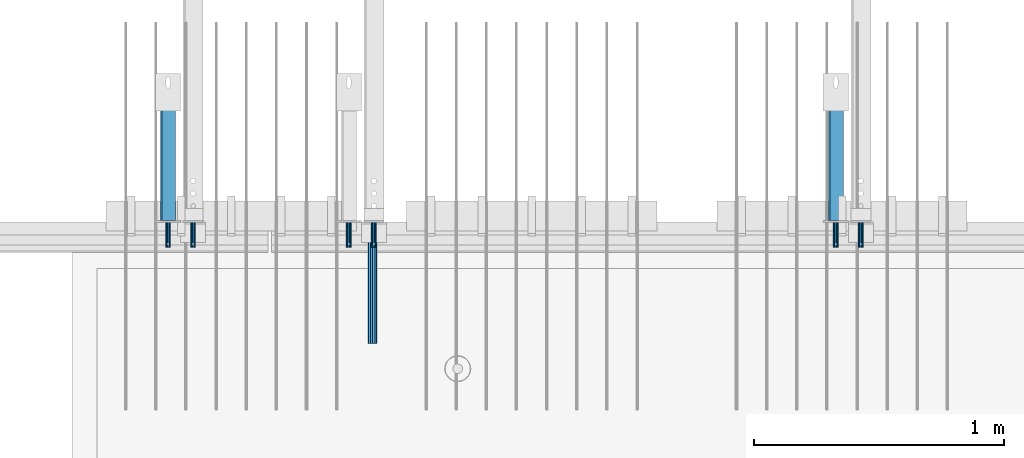
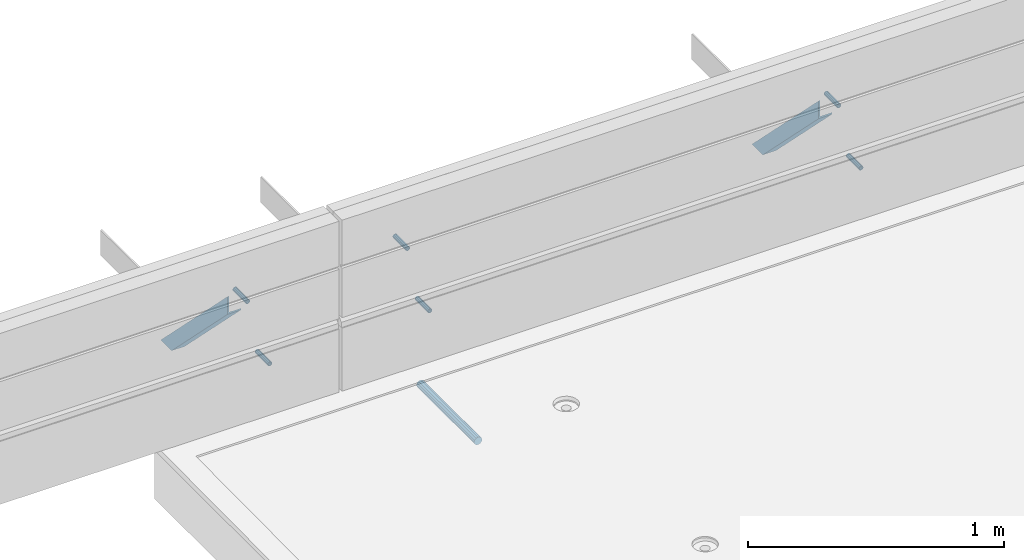
# One storey, part 50 of 153: 7 beams, 2 members, 12 elements without a shape of their own.
"""IFC2X3 building model written with IfcOpenShell, lengths in millimetres."""

from ifc_helpers import new_model, si_unit, frame, origin_with_axes, place, context, subcontext, project, spatial, faceted_brep, material, type_object, element, aggregate, save


model = new_model("IFC2X3")

# Units and contexts
model_context = context("Model", 3, precision=1e-05, world=origin_with_axes())
body_context = subcontext(model_context, "Body", "Model", "MODEL_VIEW")
ifc_project = project(units=[si_unit("LENGTHUNIT", "METRE", prefix="MILLI"), si_unit("AREAUNIT", "SQUARE_METRE"), si_unit("VOLUMEUNIT", "CUBIC_METRE"), si_unit("MASSUNIT", "GRAM", prefix="KILO"), si_unit("TIMEUNIT", "SECOND"), si_unit("PLANEANGLEUNIT", "RADIAN"), si_unit("SOLIDANGLEUNIT", "STERADIAN"), si_unit("THERMODYNAMICTEMPERATUREUNIT", "DEGREE_CELSIUS"), si_unit("LUMINOUSINTENSITYUNIT", "LUMEN")], contexts=[model_context])

# Site, building, storey
site_placement = place(None, origin_with_axes())
site = spatial("IfcSite", under=ifc_project, at=site_placement, CompositionType="ELEMENT")
building_placement = place(site_placement, origin_with_axes())
building = spatial("IfcBuilding", under=site, at=building_placement, CompositionType="ELEMENT")
storey_placement = place(building_placement, origin_with_axes())
storey = spatial("IfcBuildingStorey", under=building, at=storey_placement, Name="8", CompositionType="ELEMENT", Elevation=0.0)

# Assemblies, beams
assembly_1_placement = place(storey_placement, origin_with_axes())
assembly_1 = element("IfcElementAssembly", 1, at=assembly_1_placement, inside=storey, AssemblyPlace="NOTDEFINED", PredefinedType="REINFORCEMENT_UNIT")
assembly_2_placement = place(assembly_1_placement, origin_with_axes())
assembly_2 = element("IfcElementAssembly", 2, at=assembly_2_placement, Name="Steel Assembly", AssemblyPlace="NOTDEFINED", PredefinedType="RIGID_FRAME")
ifc_material_1 = material(Name="STEEL/Steel_Undefined")
beam_type_1 = type_object("IfcBeamType", PredefinedType="NOTDEFINED")
beam_1_placement = place(assembly_2_placement, frame((28925.0, 7665.0, 103315.0), z_axis=(1.0, 0.0, 0.0), x_axis=(0.0, -1.0, 0.0)))
beam_1 = element("IfcBeam", 3, at=beam_1_placement, type_object=beam_type_1, material=ifc_material_1, Name="1036-G", context=body_context, shape_type="Brep", body=[
    faceted_brep([(0.0, -8.49999999999272, -1.45519152283669e-11), (0.0, -7.36121593215648, 4.24999999998545), (100.000000000262, -7.36121593215648, 4.24999999998545), (100.000000000262, -8.49999999999272, -1.45519152283669e-11), (0.0, -4.24999999998545, 7.36121593216376), (100.000000000262, -4.24999999998545, 7.36121593216376), (0.0, 1.45519152283669e-11, 8.49999999998545), (100.000000000262, 1.45519152283669e-11, 8.49999999998545), (0.0, 4.25000000001455, 7.36121593216376), (100.000000000262, 4.25000000001455, 7.36121593216376), (0.0, 7.36121593217104, 4.24999999998545), (100.000000000262, 7.36121593217104, 4.24999999998545), (0.0, 8.50000000000728, 0.0), (100.000000000262, 8.50000000000728, 0.0), (0.0, 7.36121593217104, -4.25000000001455), (100.000000000262, 7.36121593217104, -4.25000000001455), (0.0, 4.25000000000728, -7.36121593219286), (100.000000000262, 4.25000000000728, -7.36121593219286), (0.0, 7.27595761418343e-12, -8.5), (100.000000000262, 7.27595761418343e-12, -8.5), (0.0, -4.24999999999272, -7.36121593217831), (100.000000000262, -4.24999999999272, -7.36121593217831), (0.0, -7.36121593215648, -4.25), (100.000000000262, -7.36121593215648, -4.25), (0.0, -10.4999999999927, -1.45519152283669e-11), (0.0, -9.09326673972828, -5.25000000001455), (100.000000000262, -9.09326673972828, -5.25000000001455), (100.000000000262, -10.4999999999927, -1.45519152283669e-11), (0.0, -5.24999999998545, -9.09326673974283), (100.000000000262, -5.24999999998545, -9.09326673974283), (0.0, 7.27595761418343e-12, -10.5), (100.000000000262, 7.27595761418343e-12, -10.5), (0.0, 5.25000000001455, -9.09326673975738), (100.000000000262, 5.25000000001455, -9.09326673975738), (0.0, 9.09326673975011, -5.25000000001455), (100.000000000262, 9.09326673975011, -5.25000000001455), (0.0, 10.5000000000073, -1.45519152283669e-11), (100.000000000262, 10.5000000000073, -1.45519152283669e-11), (0.0, 9.09326673975011, 5.25), (100.000000000262, 9.09326673975011, 5.25), (0.0, 5.25000000000728, 9.09326673972828), (100.000000000262, 5.25000000000728, 9.09326673972828), (0.0, 1.45519152283669e-11, 10.4999999999854), (100.000000000262, 1.45519152283669e-11, 10.4999999999854), (0.0, -5.24999999999272, 9.09326673972828), (100.000000000262, -5.24999999999272, 9.09326673972828), (0.0, -9.09326673972828, 5.24999999998545), (100.000000000262, -9.09326673972828, 5.24999999998545)], [[[0, 1, 2, 3]], [[1, 4, 5, 2]], [[4, 6, 7, 5]], [[6, 8, 9, 7]], [[8, 10, 11, 9]], [[10, 12, 13, 11]], [[12, 14, 15, 13]], [[14, 16, 17, 15]], [[16, 18, 19, 17]], [[18, 20, 21, 19]], [[20, 22, 23, 21]], [[22, 0, 3, 23]], [[24, 25, 26, 27]], [[25, 28, 29, 26]], [[28, 30, 31, 29]], [[30, 32, 33, 31]], [[32, 34, 35, 33]], [[34, 36, 37, 35]], [[36, 38, 39, 37]], [[38, 40, 41, 39]], [[40, 42, 43, 41]], [[42, 44, 45, 43]], [[44, 46, 47, 45]], [[46, 24, 27, 47]], [[29, 31, 33, 35, 37, 39, 41, 43, 45, 47, 27, 26], [5, 7, 9, 11, 13, 15, 17, 19, 21, 23, 3, 2]], [[46, 44, 42, 40, 38, 36, 34, 32, 30, 28, 25, 24], [22, 20, 18, 16, 14, 12, 10, 8, 6, 4, 1, 0]]]),
])
aggregate(assembly_2, [beam_1])
assembly_3_placement = place(assembly_1_placement, origin_with_axes())
assembly_3 = element("IfcElementAssembly", 4, at=assembly_3_placement, Name="Steel Assembly", AssemblyPlace="NOTDEFINED", PredefinedType="RIGID_FRAME")
beam_2_placement = place(assembly_3_placement, frame((29025.0, 7665.0, 102983.0), z_axis=(1.0, 0.0, 0.0), x_axis=(0.0, -1.0, 0.0)))
beam_2 = element("IfcBeam", 5, at=beam_2_placement, type_object=beam_type_1, material=ifc_material_1, Name="1036-G", context=body_context, shape_type="Brep", body=[
    faceted_brep([(0.0, -8.49999999999272, -1.45519152283669e-11), (0.0, -7.36121593215648, 4.24999999998545), (100.000000000262, -7.36121593215648, 4.24999999998545), (100.000000000262, -8.49999999999272, -1.45519152283669e-11), (0.0, -4.24999999998545, 7.36121593216376), (100.000000000262, -4.24999999998545, 7.36121593216376), (0.0, 1.45519152283669e-11, 8.49999999998545), (100.000000000262, 1.45519152283669e-11, 8.49999999998545), (0.0, 4.25000000001455, 7.36121593216376), (100.000000000262, 4.25000000001455, 7.36121593216376), (0.0, 7.36121593217104, 4.24999999998545), (100.000000000262, 7.36121593217104, 4.24999999998545), (0.0, 8.50000000000728, 0.0), (100.000000000262, 8.50000000000728, 0.0), (0.0, 7.36121593217104, -4.25000000001455), (100.000000000262, 7.36121593217104, -4.25000000001455), (0.0, 4.25000000000728, -7.36121593219286), (100.000000000262, 4.25000000000728, -7.36121593219286), (0.0, 7.27595761418343e-12, -8.5), (100.000000000262, 7.27595761418343e-12, -8.5), (0.0, -4.24999999999272, -7.36121593217831), (100.000000000262, -4.24999999999272, -7.36121593217831), (0.0, -7.36121593215648, -4.25), (100.000000000262, -7.36121593215648, -4.25), (0.0, -10.4999999999927, -1.45519152283669e-11), (0.0, -9.09326673972828, -5.25000000001455), (100.000000000262, -9.09326673972828, -5.25000000001455), (100.000000000262, -10.4999999999927, -1.45519152283669e-11), (0.0, -5.24999999998545, -9.09326673974283), (100.000000000262, -5.24999999998545, -9.09326673974283), (0.0, 7.27595761418343e-12, -10.5), (100.000000000262, 7.27595761418343e-12, -10.5), (0.0, 5.25000000001455, -9.09326673975738), (100.000000000262, 5.25000000001455, -9.09326673975738), (0.0, 9.09326673975011, -5.25000000001455), (100.000000000262, 9.09326673975011, -5.25000000001455), (0.0, 10.5000000000073, -1.45519152283669e-11), (100.000000000262, 10.5000000000073, -1.45519152283669e-11), (0.0, 9.09326673975011, 5.25), (100.000000000262, 9.09326673975011, 5.25), (0.0, 5.25000000000728, 9.09326673972828), (100.000000000262, 5.25000000000728, 9.09326673972828), (0.0, 1.45519152283669e-11, 10.4999999999854), (100.000000000262, 1.45519152283669e-11, 10.4999999999854), (0.0, -5.24999999999272, 9.09326673972828), (100.000000000262, -5.24999999999272, 9.09326673972828), (0.0, -9.09326673972828, 5.24999999998545), (100.000000000262, -9.09326673972828, 5.24999999998545)], [[[0, 1, 2, 3]], [[1, 4, 5, 2]], [[4, 6, 7, 5]], [[6, 8, 9, 7]], [[8, 10, 11, 9]], [[10, 12, 13, 11]], [[12, 14, 15, 13]], [[14, 16, 17, 15]], [[16, 18, 19, 17]], [[18, 20, 21, 19]], [[20, 22, 23, 21]], [[22, 0, 3, 23]], [[24, 25, 26, 27]], [[25, 28, 29, 26]], [[28, 30, 31, 29]], [[30, 32, 33, 31]], [[32, 34, 35, 33]], [[34, 36, 37, 35]], [[36, 38, 39, 37]], [[38, 40, 41, 39]], [[40, 42, 43, 41]], [[42, 44, 45, 43]], [[44, 46, 47, 45]], [[46, 24, 27, 47]], [[29, 31, 33, 35, 37, 39, 41, 43, 45, 47, 27, 26], [5, 7, 9, 11, 13, 15, 17, 19, 21, 23, 3, 2]], [[46, 44, 42, 40, 38, 36, 34, 32, 30, 28, 25, 24], [22, 20, 18, 16, 14, 12, 10, 8, 6, 4, 1, 0]]]),
])
aggregate(assembly_3, [beam_2])
assembly_4_placement = place(assembly_1_placement, origin_with_axes())
assembly_4 = element("IfcElementAssembly", 6, at=assembly_4_placement, Name="Steel Assembly", AssemblyPlace="NOTDEFINED", PredefinedType="RIGID_FRAME")
beam_3_placement = place(assembly_4_placement, frame((30870.0, 7665.0, 103315.0), z_axis=(1.0, 0.0, 0.0), x_axis=(0.0, -1.0, 0.0)))
beam_3 = element("IfcBeam", 7, at=beam_3_placement, type_object=beam_type_1, material=ifc_material_1, Name="1036-G", context=body_context, shape_type="Brep", body=[
    faceted_brep([(0.0, -8.49999999999272, -1.45519152283669e-11), (0.0, -7.36121593215648, 4.24999999998545), (100.000000000262, -7.36121593215648, 4.24999999998545), (100.000000000262, -8.49999999999272, -1.45519152283669e-11), (0.0, -4.24999999998545, 7.36121593216376), (100.000000000262, -4.24999999998545, 7.36121593216376), (0.0, 1.45519152283669e-11, 8.49999999998545), (100.000000000262, 1.45519152283669e-11, 8.49999999998545), (0.0, 4.25000000001455, 7.36121593216376), (100.000000000262, 4.25000000001455, 7.36121593216376), (0.0, 7.36121593217104, 4.24999999998545), (100.000000000262, 7.36121593217104, 4.24999999998545), (0.0, 8.50000000000728, 0.0), (100.000000000262, 8.50000000000728, 0.0), (0.0, 7.36121593217104, -4.25000000001455), (100.000000000262, 7.36121593217104, -4.25000000001455), (0.0, 4.25000000000728, -7.36121593219286), (100.000000000262, 4.25000000000728, -7.36121593219286), (0.0, 7.27595761418343e-12, -8.5), (100.000000000262, 7.27595761418343e-12, -8.5), (0.0, -4.24999999999272, -7.36121593217831), (100.000000000262, -4.24999999999272, -7.36121593217831), (0.0, -7.36121593215648, -4.25), (100.000000000262, -7.36121593215648, -4.25), (0.0, -10.4999999999927, -1.45519152283669e-11), (0.0, -9.09326673972828, -5.25000000001455), (100.000000000262, -9.09326673972828, -5.25000000001455), (100.000000000262, -10.4999999999927, -1.45519152283669e-11), (0.0, -5.24999999998545, -9.09326673974283), (100.000000000262, -5.24999999998545, -9.09326673974283), (0.0, 7.27595761418343e-12, -10.5), (100.000000000262, 7.27595761418343e-12, -10.5), (0.0, 5.25000000001455, -9.09326673975738), (100.000000000262, 5.25000000001455, -9.09326673975738), (0.0, 9.09326673975011, -5.25000000001455), (100.000000000262, 9.09326673975011, -5.25000000001455), (0.0, 10.5000000000073, -1.45519152283669e-11), (100.000000000262, 10.5000000000073, -1.45519152283669e-11), (0.0, 9.09326673975011, 5.25), (100.000000000262, 9.09326673975011, 5.25), (0.0, 5.25000000000728, 9.09326673972828), (100.000000000262, 5.25000000000728, 9.09326673972828), (0.0, 1.45519152283669e-11, 10.4999999999854), (100.000000000262, 1.45519152283669e-11, 10.4999999999854), (0.0, -5.24999999999272, 9.09326673972828), (100.000000000262, -5.24999999999272, 9.09326673972828), (0.0, -9.09326673972828, 5.24999999998545), (100.000000000262, -9.09326673972828, 5.24999999998545)], [[[0, 1, 2, 3]], [[1, 4, 5, 2]], [[4, 6, 7, 5]], [[6, 8, 9, 7]], [[8, 10, 11, 9]], [[10, 12, 13, 11]], [[12, 14, 15, 13]], [[14, 16, 17, 15]], [[16, 18, 19, 17]], [[18, 20, 21, 19]], [[20, 22, 23, 21]], [[22, 0, 3, 23]], [[24, 25, 26, 27]], [[25, 28, 29, 26]], [[28, 30, 31, 29]], [[30, 32, 33, 31]], [[32, 34, 35, 33]], [[34, 36, 37, 35]], [[36, 38, 39, 37]], [[38, 40, 41, 39]], [[40, 42, 43, 41]], [[42, 44, 45, 43]], [[44, 46, 47, 45]], [[46, 24, 27, 47]], [[29, 31, 33, 35, 37, 39, 41, 43, 45, 47, 27, 26], [5, 7, 9, 11, 13, 15, 17, 19, 21, 23, 3, 2]], [[46, 44, 42, 40, 38, 36, 34, 32, 30, 28, 25, 24], [22, 20, 18, 16, 14, 12, 10, 8, 6, 4, 1, 0]]]),
])
aggregate(assembly_4, [beam_3])
assembly_5_placement = place(assembly_1_placement, origin_with_axes())
assembly_5 = element("IfcElementAssembly", 8, at=assembly_5_placement, Name="Steel Assembly", AssemblyPlace="NOTDEFINED", PredefinedType="RIGID_FRAME")
aggregate(assembly_1, [assembly_2, assembly_3, assembly_4, assembly_5])
beam_4_placement = place(assembly_5_placement, frame((30970.0, 7665.0, 102983.0), z_axis=(1.0, 0.0, 0.0), x_axis=(0.0, -1.0, 0.0)))
beam_4 = element("IfcBeam", 9, at=beam_4_placement, type_object=beam_type_1, material=ifc_material_1, Name="1036-G", context=body_context, shape_type="Brep", body=[
    faceted_brep([(0.0, -8.49999999999272, -1.45519152283669e-11), (0.0, -7.36121593215648, 4.24999999998545), (100.000000000262, -7.36121593215648, 4.24999999998545), (100.000000000262, -8.49999999999272, -1.45519152283669e-11), (0.0, -4.24999999998545, 7.36121593216376), (100.000000000262, -4.24999999998545, 7.36121593216376), (0.0, 1.45519152283669e-11, 8.49999999998545), (100.000000000262, 1.45519152283669e-11, 8.49999999998545), (0.0, 4.25000000001455, 7.36121593216376), (100.000000000262, 4.25000000001455, 7.36121593216376), (0.0, 7.36121593217104, 4.24999999998545), (100.000000000262, 7.36121593217104, 4.24999999998545), (0.0, 8.50000000000728, 0.0), (100.000000000262, 8.50000000000728, 0.0), (0.0, 7.36121593217104, -4.25000000001455), (100.000000000262, 7.36121593217104, -4.25000000001455), (0.0, 4.25000000000728, -7.36121593219286), (100.000000000262, 4.25000000000728, -7.36121593219286), (0.0, 7.27595761418343e-12, -8.5), (100.000000000262, 7.27595761418343e-12, -8.5), (0.0, -4.24999999999272, -7.36121593217831), (100.000000000262, -4.24999999999272, -7.36121593217831), (0.0, -7.36121593215648, -4.25), (100.000000000262, -7.36121593215648, -4.25), (0.0, -10.4999999999927, -1.45519152283669e-11), (0.0, -9.09326673972828, -5.25000000001455), (100.000000000262, -9.09326673972828, -5.25000000001455), (100.000000000262, -10.4999999999927, -1.45519152283669e-11), (0.0, -5.24999999998545, -9.09326673974283), (100.000000000262, -5.24999999998545, -9.09326673974283), (0.0, 7.27595761418343e-12, -10.5), (100.000000000262, 7.27595761418343e-12, -10.5), (0.0, 5.25000000001455, -9.09326673975738), (100.000000000262, 5.25000000001455, -9.09326673975738), (0.0, 9.09326673975011, -5.25000000001455), (100.000000000262, 9.09326673975011, -5.25000000001455), (0.0, 10.5000000000073, -1.45519152283669e-11), (100.000000000262, 10.5000000000073, -1.45519152283669e-11), (0.0, 9.09326673975011, 5.25), (100.000000000262, 9.09326673975011, 5.25), (0.0, 5.25000000000728, 9.09326673972828), (100.000000000262, 5.25000000000728, 9.09326673972828), (0.0, 1.45519152283669e-11, 10.4999999999854), (100.000000000262, 1.45519152283669e-11, 10.4999999999854), (0.0, -5.24999999999272, 9.09326673972828), (100.000000000262, -5.24999999999272, 9.09326673972828), (0.0, -9.09326673972828, 5.24999999998545), (100.000000000262, -9.09326673972828, 5.24999999998545)], [[[0, 1, 2, 3]], [[1, 4, 5, 2]], [[4, 6, 7, 5]], [[6, 8, 9, 7]], [[8, 10, 11, 9]], [[10, 12, 13, 11]], [[12, 14, 15, 13]], [[14, 16, 17, 15]], [[16, 18, 19, 17]], [[18, 20, 21, 19]], [[20, 22, 23, 21]], [[22, 0, 3, 23]], [[24, 25, 26, 27]], [[25, 28, 29, 26]], [[28, 30, 31, 29]], [[30, 32, 33, 31]], [[32, 34, 35, 33]], [[34, 36, 37, 35]], [[36, 38, 39, 37]], [[38, 40, 41, 39]], [[40, 42, 43, 41]], [[42, 44, 45, 43]], [[44, 46, 47, 45]], [[46, 24, 27, 47]], [[29, 31, 33, 35, 37, 39, 41, 43, 45, 47, 27, 26], [5, 7, 9, 11, 13, 15, 17, 19, 21, 23, 3, 2]], [[46, 44, 42, 40, 38, 36, 34, 32, 30, 28, 25, 24], [22, 20, 18, 16, 14, 12, 10, 8, 6, 4, 1, 0]]]),
])
aggregate(assembly_5, [beam_4])

assembly_6_placement = place(storey_placement, origin_with_axes())
assembly_6 = element("IfcElementAssembly", 10, at=assembly_6_placement, inside=storey, AssemblyPlace="NOTDEFINED", PredefinedType="REINFORCEMENT_UNIT")
assembly_7_placement = place(assembly_6_placement, origin_with_axes())
assembly_7 = element("IfcElementAssembly", 11, at=assembly_7_placement, Name="Steel Assembly", AssemblyPlace="NOTDEFINED", PredefinedType="RIGID_FRAME")
beam_5_placement = place(assembly_7_placement, frame((28203.0, 7665.0, 103315.0), z_axis=(1.0, 0.0, 0.0), x_axis=(0.0, -1.0, 0.0)))
beam_5 = element("IfcBeam", 12, at=beam_5_placement, type_object=beam_type_1, material=ifc_material_1, Name="1036-G", context=body_context, shape_type="Brep", body=[
    faceted_brep([(0.0, -8.49999999999272, -1.45519152283669e-11), (0.0, -7.36121593215648, 4.24999999998545), (100.000000000262, -7.36121593215648, 4.24999999998545), (100.000000000262, -8.49999999999272, -1.45519152283669e-11), (0.0, -4.24999999998545, 7.36121593216376), (100.000000000262, -4.24999999998545, 7.36121593216376), (0.0, 1.45519152283669e-11, 8.49999999998545), (100.000000000262, 1.45519152283669e-11, 8.49999999998545), (0.0, 4.25000000001455, 7.36121593216376), (100.000000000262, 4.25000000001455, 7.36121593216376), (0.0, 7.36121593217104, 4.24999999998545), (100.000000000262, 7.36121593217104, 4.24999999998545), (0.0, 8.50000000000728, 0.0), (100.000000000262, 8.50000000000728, 0.0), (0.0, 7.36121593217104, -4.25000000001455), (100.000000000262, 7.36121593217104, -4.25000000001455), (0.0, 4.25000000000728, -7.36121593219286), (100.000000000262, 4.25000000000728, -7.36121593219286), (0.0, 7.27595761418343e-12, -8.5), (100.000000000262, 7.27595761418343e-12, -8.5), (0.0, -4.24999999999272, -7.36121593217831), (100.000000000262, -4.24999999999272, -7.36121593217831), (0.0, -7.36121593215648, -4.25), (100.000000000262, -7.36121593215648, -4.25), (0.0, -10.4999999999927, -1.45519152283669e-11), (0.0, -9.09326673972828, -5.25000000001455), (100.000000000262, -9.09326673972828, -5.25000000001455), (100.000000000262, -10.4999999999927, -1.45519152283669e-11), (0.0, -5.24999999998545, -9.09326673974283), (100.000000000262, -5.24999999998545, -9.09326673974283), (0.0, 7.27595761418343e-12, -10.5), (100.000000000262, 7.27595761418343e-12, -10.5), (0.0, 5.25000000001455, -9.09326673975738), (100.000000000262, 5.25000000001455, -9.09326673975738), (0.0, 9.09326673975011, -5.25000000001455), (100.000000000262, 9.09326673975011, -5.25000000001455), (0.0, 10.5000000000073, -1.45519152283669e-11), (100.000000000262, 10.5000000000073, -1.45519152283669e-11), (0.0, 9.09326673975011, 5.25), (100.000000000262, 9.09326673975011, 5.25), (0.0, 5.25000000000728, 9.09326673972828), (100.000000000262, 5.25000000000728, 9.09326673972828), (0.0, 1.45519152283669e-11, 10.4999999999854), (100.000000000262, 1.45519152283669e-11, 10.4999999999854), (0.0, -5.24999999999272, 9.09326673972828), (100.000000000262, -5.24999999999272, 9.09326673972828), (0.0, -9.09326673972828, 5.24999999998545), (100.000000000262, -9.09326673972828, 5.24999999998545)], [[[0, 1, 2, 3]], [[1, 4, 5, 2]], [[4, 6, 7, 5]], [[6, 8, 9, 7]], [[8, 10, 11, 9]], [[10, 12, 13, 11]], [[12, 14, 15, 13]], [[14, 16, 17, 15]], [[16, 18, 19, 17]], [[18, 20, 21, 19]], [[20, 22, 23, 21]], [[22, 0, 3, 23]], [[24, 25, 26, 27]], [[25, 28, 29, 26]], [[28, 30, 31, 29]], [[30, 32, 33, 31]], [[32, 34, 35, 33]], [[34, 36, 37, 35]], [[36, 38, 39, 37]], [[38, 40, 41, 39]], [[40, 42, 43, 41]], [[42, 44, 45, 43]], [[44, 46, 47, 45]], [[46, 24, 27, 47]], [[29, 31, 33, 35, 37, 39, 41, 43, 45, 47, 27, 26], [5, 7, 9, 11, 13, 15, 17, 19, 21, 23, 3, 2]], [[46, 44, 42, 40, 38, 36, 34, 32, 30, 28, 25, 24], [22, 20, 18, 16, 14, 12, 10, 8, 6, 4, 1, 0]]]),
])
aggregate(assembly_7, [beam_5])
assembly_8_placement = place(assembly_6_placement, origin_with_axes())
assembly_8 = element("IfcElementAssembly", 13, at=assembly_8_placement, Name="Steel Assembly", AssemblyPlace="NOTDEFINED", PredefinedType="RIGID_FRAME")
aggregate(assembly_6, [assembly_7, assembly_8])
beam_6_placement = place(assembly_8_placement, frame((28303.0, 7665.0, 102983.0), z_axis=(1.0, 0.0, 0.0), x_axis=(0.0, -1.0, 0.0)))
beam_6 = element("IfcBeam", 14, at=beam_6_placement, type_object=beam_type_1, material=ifc_material_1, Name="1036-G", context=body_context, shape_type="Brep", body=[
    faceted_brep([(0.0, -8.49999999999272, -1.45519152283669e-11), (0.0, -7.36121593215648, 4.24999999998545), (100.000000000262, -7.36121593215648, 4.24999999998545), (100.000000000262, -8.49999999999272, -1.45519152283669e-11), (0.0, -4.24999999998545, 7.36121593216376), (100.000000000262, -4.24999999998545, 7.36121593216376), (0.0, 1.45519152283669e-11, 8.49999999998545), (100.000000000262, 1.45519152283669e-11, 8.49999999998545), (0.0, 4.25000000001455, 7.36121593216376), (100.000000000262, 4.25000000001455, 7.36121593216376), (0.0, 7.36121593217104, 4.24999999998545), (100.000000000262, 7.36121593217104, 4.24999999998545), (0.0, 8.50000000000728, 0.0), (100.000000000262, 8.50000000000728, 0.0), (0.0, 7.36121593217104, -4.25000000001455), (100.000000000262, 7.36121593217104, -4.25000000001455), (0.0, 4.25000000000728, -7.36121593219286), (100.000000000262, 4.25000000000728, -7.36121593219286), (0.0, 7.27595761418343e-12, -8.5), (100.000000000262, 7.27595761418343e-12, -8.5), (0.0, -4.24999999999272, -7.36121593217831), (100.000000000262, -4.24999999999272, -7.36121593217831), (0.0, -7.36121593215648, -4.25), (100.000000000262, -7.36121593215648, -4.25), (0.0, -10.4999999999927, -1.45519152283669e-11), (0.0, -9.09326673972828, -5.25000000001455), (100.000000000262, -9.09326673972828, -5.25000000001455), (100.000000000262, -10.4999999999927, -1.45519152283669e-11), (0.0, -5.24999999998545, -9.09326673974283), (100.000000000262, -5.24999999998545, -9.09326673974283), (0.0, 7.27595761418343e-12, -10.5), (100.000000000262, 7.27595761418343e-12, -10.5), (0.0, 5.25000000001455, -9.09326673975738), (100.000000000262, 5.25000000001455, -9.09326673975738), (0.0, 9.09326673975011, -5.25000000001455), (100.000000000262, 9.09326673975011, -5.25000000001455), (0.0, 10.5000000000073, -1.45519152283669e-11), (100.000000000262, 10.5000000000073, -1.45519152283669e-11), (0.0, 9.09326673975011, 5.25), (100.000000000262, 9.09326673975011, 5.25), (0.0, 5.25000000000728, 9.09326673972828), (100.000000000262, 5.25000000000728, 9.09326673972828), (0.0, 1.45519152283669e-11, 10.4999999999854), (100.000000000262, 1.45519152283669e-11, 10.4999999999854), (0.0, -5.24999999999272, 9.09326673972828), (100.000000000262, -5.24999999999272, 9.09326673972828), (0.0, -9.09326673972828, 5.24999999998545), (100.000000000262, -9.09326673972828, 5.24999999998545)], [[[0, 1, 2, 3]], [[1, 4, 5, 2]], [[4, 6, 7, 5]], [[6, 8, 9, 7]], [[8, 10, 11, 9]], [[10, 12, 13, 11]], [[12, 14, 15, 13]], [[14, 16, 17, 15]], [[16, 18, 19, 17]], [[18, 20, 21, 19]], [[20, 22, 23, 21]], [[22, 0, 3, 23]], [[24, 25, 26, 27]], [[25, 28, 29, 26]], [[28, 30, 31, 29]], [[30, 32, 33, 31]], [[32, 34, 35, 33]], [[34, 36, 37, 35]], [[36, 38, 39, 37]], [[38, 40, 41, 39]], [[40, 42, 43, 41]], [[42, 44, 45, 43]], [[44, 46, 47, 45]], [[46, 24, 27, 47]], [[29, 31, 33, 35, 37, 39, 41, 43, 45, 47, 27, 26], [5, 7, 9, 11, 13, 15, 17, 19, 21, 23, 3, 2]], [[46, 44, 42, 40, 38, 36, 34, 32, 30, 28, 25, 24], [22, 20, 18, 16, 14, 12, 10, 8, 6, 4, 1, 0]]]),
])
aggregate(assembly_8, [beam_6])

# Assembly, member
assembly_9_placement = place(storey_placement, origin_with_axes())
assembly_9 = element("IfcElementAssembly", 15, at=assembly_9_placement, inside=storey, Name="Steel Assembly", AssemblyPlace="NOTDEFINED", PredefinedType="RIGID_FRAME")
ifc_material_2 = material(Name="STEEL/S355J2")
member_type = type_object("IfcMemberType", PredefinedType="NOTDEFINED")
member_1_placement = place(assembly_9_placement, frame((30870.0, 7649.75675675785, 103263.816878981), z_axis=(0.0, 0.708108108195998, 0.706104034195447), x_axis=(0.0, 0.706104034195443, -0.708108108196002)))
member_1 = element("IfcMember", 16, at=member_1_placement, type_object=member_type, material=ifc_material_2, Name="2", context=body_context, shape_type="Brep", body=[
    faceted_brep([(60.1702928045706, 30.0, -30.0), (-5.28234522789717e-09, 30.0, 30.0), (739.999999918371, 30.0, 30.0000000000146), (680.169810768777, 30.0, -30.0), (-5.28234522789717e-09, 24.0, 30.0), (739.999999918371, 24.0, 30.0000000000146), (54.1532635235926, 24.0, -24.0), (686.152829683742, 24.0, -23.9999999999854), (54.1532635235926, -30.0, -24.0), (686.152829683742, -30.0, -23.9999999999854), (60.1702928045706, -30.0, -30.0), (680.169810768777, -30.0, -30.0)], [[[0, 1, 2, 3]], [[1, 4, 5, 2]], [[4, 6, 7, 5]], [[6, 8, 9, 7]], [[8, 10, 11, 9]], [[10, 0, 3, 11]], [[5, 7, 9, 11, 3, 2]], [[10, 8, 6, 4, 1, 0]]]),
])
aggregate(assembly_9, [member_1])

assembly_10_placement = place(storey_placement, origin_with_axes())
assembly_10 = element("IfcElementAssembly", 17, at=assembly_10_placement, inside=storey, Name="Steel Assembly", AssemblyPlace="NOTDEFINED", PredefinedType="RIGID_FRAME")
member_2_placement = place(assembly_10_placement, frame((28203.0, 7649.75675675785, 103263.816878981), z_axis=(0.0, 0.708108108195998, 0.706104034195447), x_axis=(0.0, 0.706104034195443, -0.708108108196002)))
member_2 = element("IfcMember", 18, at=member_2_placement, type_object=member_type, material=ifc_material_2, Name="2", context=body_context, shape_type="Brep", body=[
    faceted_brep([(60.1702928045706, 30.0, -30.0), (-5.28234522789717e-09, 30.0, 30.0), (739.999999918371, 30.0, 30.0000000000146), (680.169810768777, 30.0, -30.0), (-5.28234522789717e-09, 24.0, 30.0), (739.999999918371, 24.0, 30.0000000000146), (54.1532635235926, 24.0, -24.0), (686.152829683742, 24.0, -23.9999999999854), (54.1532635235926, -30.0, -24.0), (686.152829683742, -30.0, -23.9999999999854), (60.1702928045706, -30.0, -30.0), (680.169810768777, -30.0, -30.0)], [[[0, 1, 2, 3]], [[1, 4, 5, 2]], [[4, 6, 7, 5]], [[6, 8, 9, 7]], [[8, 10, 11, 9]], [[10, 0, 3, 11]], [[5, 7, 9, 11, 3, 2]], [[10, 8, 6, 4, 1, 0]]]),
])
aggregate(assembly_10, [member_2])

# Assemblies, beam
assembly_11_placement = place(storey_placement, origin_with_axes())
assembly_11 = element("IfcElementAssembly", 19, at=assembly_11_placement, inside=storey, AssemblyPlace="NOTDEFINED", PredefinedType="REINFORCEMENT_UNIT")
assembly_12_placement = place(assembly_11_placement, origin_with_axes())
assembly_12 = element("IfcElementAssembly", 20, at=assembly_12_placement, Name="Steel Assembly", AssemblyPlace="NOTDEFINED", PredefinedType="RIGID_FRAME")
aggregate(assembly_11, [assembly_12])
ifc_material_3 = material(Name="STEEL/S235JR")
beam_type_2 = type_object("IfcBeamType", Name="D36", PredefinedType="NOTDEFINED")
beam_7_placement = place(assembly_12_placement, frame((29020.0001429934, 7630.01478639016, 102598.0), z_axis=(0.0, 0.0, 1.0), x_axis=(0.0, -1.0, 0.0)))
beam_7 = element("IfcBeam", 21, at=beam_7_placement, type_object=beam_type_2, material=ifc_material_3, Name="Rd36", ObjectType="D36", context=body_context, shape_type="Brep", body=[
    faceted_brep([(0.0, -18.0, 0.0), (0.0, -15.5884572681207, -9.0), (450.0, -15.5884572681207, -9.0), (450.0, -18.0, 0.0), (0.0, -9.0, -15.5884572681243), (450.0, -9.0, -15.5884572681243), (0.0, 0.0, -18.0), (450.0, 0.0, -18.0), (0.0, 9.0, -15.5884572681243), (450.0, 9.0, -15.5884572681243), (0.0, 15.5884572681207, -9.0), (450.0, 15.5884572681207, -9.0), (0.0, 18.0, 0.0), (450.0, 18.0, 0.0), (0.0, 15.5884572681207, 9.0), (450.0, 15.5884572681207, 9.0), (0.0, 9.0, 15.5884572681243), (450.0, 9.0, 15.5884572681243), (0.0, 0.0, 18.0), (450.0, 0.0, 18.0), (0.0, -9.0, 15.5884572681243), (450.0, -9.0, 15.5884572681243), (0.0, -15.5884572681207, 9.0), (450.0, -15.5884572681207, 9.0)], [[[0, 1, 2, 3]], [[1, 4, 5, 2]], [[4, 6, 7, 5]], [[6, 8, 9, 7]], [[8, 10, 11, 9]], [[10, 12, 13, 11]], [[12, 14, 15, 13]], [[14, 16, 17, 15]], [[16, 18, 19, 17]], [[18, 20, 21, 19]], [[20, 22, 23, 21]], [[22, 0, 3, 23]], [[5, 7, 9, 11, 13, 15, 17, 19, 21, 23, 3, 2]], [[22, 20, 18, 16, 14, 12, 10, 8, 6, 4, 1, 0]]]),
])
aggregate(assembly_12, [beam_7])

save(model, "model.ifc")
